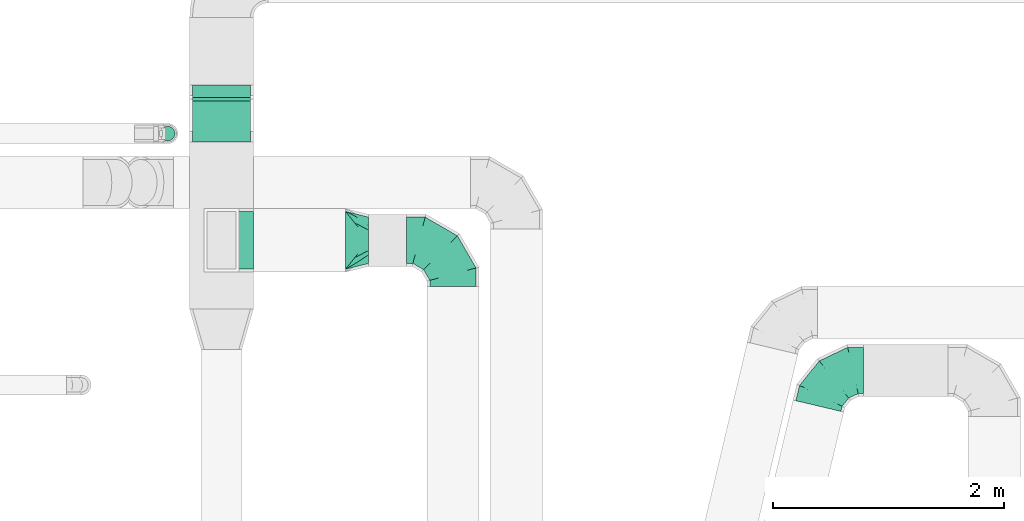
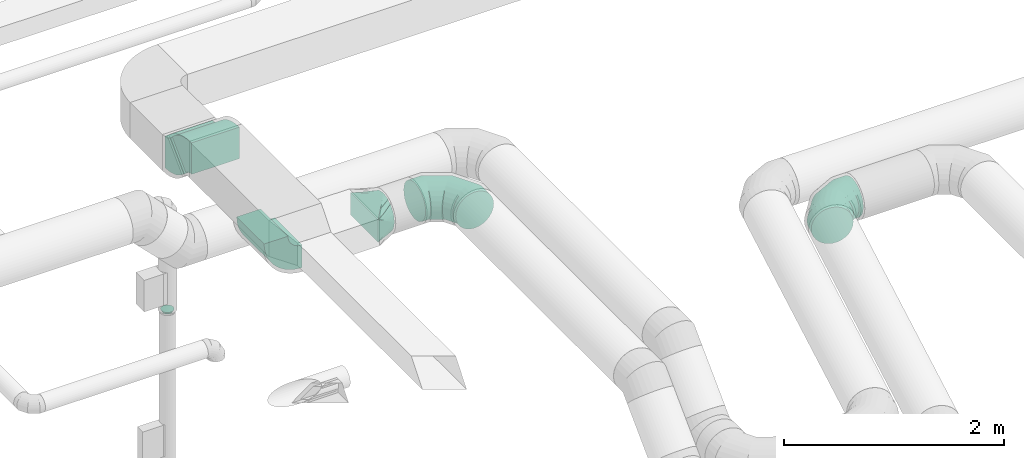
# One storey, part 54 of 97: 7 flow fittings.
"""IFC2X3 building model written with IfcOpenShell, lengths in millimetres."""

from ifc_helpers import new_model, entity, si_unit, converted_unit, derived_unit, direction, frame, frame_2d, origin, place, context, subcontext, project, spatial, polyline, circle_curve, parameter, trimmed, segment, composite_curve, outline, extrude, faceted_brep, source, transform, mapped, material, type_object, type_shapes, element, save


model = new_model("IFC2X3")

# Units and contexts
model_context = context("Model", 3, precision=0.01, world=origin(), true_north=direction((6.12303176911189e-17, 1.0)))
body_context = subcontext(model_context, "Body", "Model", "MODEL_VIEW")
ifc_project = project(units=[si_unit("LENGTHUNIT", "METRE", prefix="MILLI"), si_unit("AREAUNIT", "SQUARE_METRE"), si_unit("VOLUMEUNIT", "CUBIC_METRE"), converted_unit("PLANEANGLEUNIT", "DEGREE", entity("IfcRatioMeasure", 0.0174532925199433), si_unit("PLANEANGLEUNIT", "RADIAN"), dimensions=[0, 0, 0, 0, 0, 0, 0]), si_unit("MASSUNIT", "GRAM", prefix="KILO"), derived_unit("MASSDENSITYUNIT", [(si_unit("MASSUNIT", "GRAM", prefix="KILO"), 1), (si_unit("LENGTHUNIT", "METRE"), -3)]), derived_unit("MOMENTOFINERTIAUNIT", [(si_unit("LENGTHUNIT", "METRE"), 4)]), si_unit("TIMEUNIT", "SECOND"), si_unit("FREQUENCYUNIT", "HERTZ"), si_unit("THERMODYNAMICTEMPERATUREUNIT", "DEGREE_CELSIUS"), derived_unit("THERMALTRANSMITTANCEUNIT", [(si_unit("MASSUNIT", "GRAM", prefix="KILO"), 1), (si_unit("THERMODYNAMICTEMPERATUREUNIT", "KELVIN"), -1), (si_unit("TIMEUNIT", "SECOND"), -3)]), derived_unit("VOLUMETRICFLOWRATEUNIT", [(si_unit("LENGTHUNIT", "METRE"), 3), (si_unit("TIMEUNIT", "SECOND"), -1)]), derived_unit("MASSFLOWRATEUNIT", [(si_unit("MASSUNIT", "GRAM", prefix="KILO"), 1), (si_unit("TIMEUNIT", "SECOND"), -1)]), derived_unit("ROTATIONALFREQUENCYUNIT", [(si_unit("TIMEUNIT", "SECOND"), -1)]), si_unit("ELECTRICCURRENTUNIT", "AMPERE"), si_unit("ELECTRICVOLTAGEUNIT", "VOLT"), si_unit("POWERUNIT", "WATT"), si_unit("FORCEUNIT", "NEWTON", prefix="KILO"), si_unit("ILLUMINANCEUNIT", "LUX"), si_unit("LUMINOUSFLUXUNIT", "LUMEN"), si_unit("LUMINOUSINTENSITYUNIT", "CANDELA"), derived_unit("USERDEFINED", [(si_unit("MASSUNIT", "GRAM", prefix="KILO"), -1), (si_unit("LENGTHUNIT", "METRE"), -2), (si_unit("TIMEUNIT", "SECOND"), 3), (si_unit("LUMINOUSFLUXUNIT", "LUMEN"), 1)]), derived_unit("LINEARVELOCITYUNIT", [(si_unit("LENGTHUNIT", "METRE"), 1), (si_unit("TIMEUNIT", "SECOND"), -1)]), si_unit("PRESSUREUNIT", "PASCAL"), derived_unit("USERDEFINED", [(si_unit("LENGTHUNIT", "METRE"), -2), (si_unit("MASSUNIT", "GRAM", prefix="KILO"), 1), (si_unit("TIMEUNIT", "SECOND"), -2)]), derived_unit("LINEARFORCEUNIT", [(si_unit("MASSUNIT", "GRAM", prefix="KILO"), 1), (si_unit("LENGTHUNIT", "METRE"), 1), (si_unit("TIMEUNIT", "SECOND"), -2), (si_unit("LENGTHUNIT", "METRE"), -1)]), derived_unit("PLANARFORCEUNIT", [(si_unit("MASSUNIT", "GRAM", prefix="KILO"), 1), (si_unit("LENGTHUNIT", "METRE"), 1), (si_unit("TIMEUNIT", "SECOND"), -2), (si_unit("LENGTHUNIT", "METRE"), -2)])], contexts=[model_context])

# Site, building, storey
site_placement = place(None, origin())
site = spatial("IfcSite", under=ifc_project, at=site_placement, CompositionType="ELEMENT")
building_placement = place(site_placement, origin())
building = spatial("IfcBuilding", under=site, at=building_placement, CompositionType="ELEMENT")
storey_placement = place(building_placement, frame((0.0, 0.0, -4900.0)))
storey = spatial("IfcBuildingStorey", under=building, at=storey_placement, CompositionType="ELEMENT", Elevation=-4900.0)

# Flow fittings
ifc_material = material()
duct_fitting_type_1 = type_object("IfcDuctFittingType", PredefinedType="NOTDEFINED", material=ifc_material)
shared_shape_1 = source(origin(), body_context, "Body", "Brep", [
    faceted_brep([(-400.0, 0.0, -200.0), (-400.0, -44.5, -194.99), (-400.0, -86.78, -180.19), (-400.0, -124.7, -156.37), (-400.0, -156.37, -124.7), (-400.0, -180.19, -86.78), (-400.0, -194.99, -44.5), (-400.0, -200.0, 0.0), (-400.0, -194.99, 44.5), (-400.0, -180.19, 86.78), (-400.0, -156.37, 124.7), (-400.0, -124.7, 156.37), (-400.0, -86.78, 180.19), (-400.0, -44.5, 194.99), (-400.0, 0.0, 200.0), (-400.0, 44.5, 194.99), (-400.0, 86.78, 180.19), (-400.0, 124.7, 156.37), (-400.0, 156.37, 124.7), (-400.0, 180.19, 86.78), (-400.0, 194.99, 44.5), (-400.0, 200.0, 0.0), (-400.0, 194.99, -44.5), (-400.0, 180.19, -86.78), (-400.0, 156.37, -124.7), (-400.0, 124.7, -156.37), (-400.0, 86.78, -180.19), (-400.0, 44.5, -194.99), (-292.82, 0.0, 200.0), (-304.75, 44.5, 194.99), (-316.07, 86.78, 180.19), (-326.23, 124.7, 156.37), (-334.72, 156.37, 124.7), (-341.1, 180.19, 86.78), (-345.07, 194.99, 44.5), (-346.41, 200.0, 0.0), (-345.07, 194.99, -44.5), (-341.1, 180.19, -86.78), (-334.72, 156.37, -124.7), (-326.23, 124.7, -156.37), (-316.07, 86.78, -180.19), (-304.75, 44.5, -194.99), (-292.82, 0.0, -200.0), (-280.9, -44.5, -194.99), (-269.57, -86.78, -180.19), (-259.41, -124.7, -156.37), (-250.92, -156.37, -124.7), (-244.54, -180.19, -86.78), (-240.57, -194.99, -44.5), (-239.23, -200.0, 0.0), (-240.57, -194.99, 44.5), (-244.54, -180.19, 86.78), (-250.92, -156.37, 124.7), (-259.41, -124.7, 156.37), (-269.57, -86.78, 180.19), (-280.9, -44.5, 194.99), (-107.18, 107.18, 200.0), (-139.76, 139.76, 194.99), (-170.7, 170.7, 180.19), (-198.46, 198.46, 156.37), (-221.65, 221.65, 124.7), (-239.09, 239.09, 86.78), (-249.92, 249.92, 44.5), (-253.59, 253.59, 0.0), (-249.92, 249.92, -44.5), (-239.09, 239.09, -86.78), (-221.65, 221.65, -124.7), (-198.46, 198.46, -156.37), (-170.7, 170.7, -180.19), (-139.76, 139.76, -194.99), (-107.18, 107.18, -200.0), (-74.6, 74.6, -194.99), (-43.65, 43.65, -180.19), (-15.89, 15.89, -156.37), (7.29, -7.29, -124.7), (24.73, -24.73, -86.78), (35.56, -35.56, -44.5), (39.23, -39.23, 0.0), (35.56, -35.56, 44.5), (24.73, -24.73, 86.78), (7.29, -7.29, 124.7), (-15.89, 15.89, 156.37), (-43.65, 43.65, 180.19), (-74.6, 74.6, 194.99), (0.0, 292.82, 200.0), (-44.5, 304.75, 194.99), (-86.78, 316.07, 180.19), (-124.7, 326.23, 156.37), (-156.37, 334.72, 124.7), (-180.19, 341.1, 86.78), (-194.99, 345.07, 44.5), (-200.0, 346.41, 0.0), (-194.99, 345.07, -44.5), (-180.19, 341.1, -86.78), (-156.37, 334.72, -124.7), (-124.7, 326.23, -156.37), (-86.78, 316.07, -180.19), (-44.5, 304.75, -194.99), (0.0, 292.82, -200.0), (44.5, 280.9, -194.99), (86.78, 269.57, -180.19), (124.7, 259.41, -156.37), (156.37, 250.92, -124.7), (180.19, 244.54, -86.78), (194.99, 240.57, -44.5), (200.0, 239.23, 0.0), (194.99, 240.57, 44.5), (180.19, 244.54, 86.78), (156.37, 250.92, 124.7), (124.7, 259.41, 156.37), (86.78, 269.57, 180.19), (44.5, 280.9, 194.99), (-44.5, 400.0, -194.99), (-86.78, 400.0, -180.19), (-124.7, 400.0, -156.37), (-156.37, 400.0, -124.7), (-180.19, 400.0, -86.78), (-194.99, 400.0, -44.5), (-200.0, 400.0, 0.0), (-194.99, 400.0, 44.5), (-180.19, 400.0, 86.78), (-156.37, 400.0, 124.7), (-124.7, 400.0, 156.37), (-86.78, 400.0, 180.19), (-44.5, 400.0, 194.99), (0.0, 400.0, 200.0), (44.5, 400.0, 194.99), (86.78, 400.0, 180.19), (124.7, 400.0, 156.37), (156.37, 400.0, 124.7), (180.19, 400.0, 86.78), (194.99, 400.0, 44.5), (200.0, 400.0, 0.0), (194.99, 400.0, -44.5), (180.19, 400.0, -86.78), (156.37, 400.0, -124.7), (124.7, 400.0, -156.37), (86.78, 400.0, -180.19), (44.5, 400.0, -194.99), (0.0, 400.0, -200.0)], [[[0, 1, 2, 3, 4, 5, 6, 7, 8, 9, 10, 11, 12, 13, 14, 15, 16, 17, 18, 19, 20, 21, 22, 23, 24, 25, 26, 27]], [[28, 29, 15, 14]], [[30, 31, 17, 16]], [[29, 30, 16, 15]], [[31, 32, 18, 17]], [[32, 33, 19, 18]], [[34, 35, 21, 20]], [[33, 34, 20, 19]], [[35, 36, 22, 21]], [[37, 38, 24, 23]], [[36, 37, 23, 22]], [[38, 39, 25, 24]], [[39, 40, 26, 25]], [[41, 42, 0, 27]], [[40, 41, 27, 26]], [[1, 0, 42, 43]], [[43, 44, 2, 1]], [[45, 3, 2, 44]], [[45, 46, 4, 3]], [[5, 4, 46, 47]], [[47, 48, 6, 5]], [[49, 7, 6, 48]], [[7, 49, 50, 8]], [[8, 50, 51, 9]], [[9, 51, 52, 10]], [[52, 53, 11, 10]], [[11, 53, 54, 12]], [[12, 54, 55, 13]], [[13, 55, 28, 14]], [[56, 57, 29, 28]], [[58, 59, 31, 30]], [[57, 58, 30, 29]], [[59, 60, 32, 31]], [[60, 61, 33, 32]], [[62, 63, 35, 34]], [[61, 62, 34, 33]], [[63, 64, 36, 35]], [[65, 66, 38, 37]], [[64, 65, 37, 36]], [[66, 67, 39, 38]], [[67, 68, 40, 39]], [[69, 70, 42, 41]], [[68, 69, 41, 40]], [[43, 42, 70, 71]], [[71, 72, 44, 43]], [[73, 45, 44, 72]], [[73, 74, 46, 45]], [[47, 46, 74, 75]], [[75, 76, 48, 47]], [[77, 49, 48, 76]], [[50, 49, 77, 78]], [[51, 50, 78, 79]], [[52, 51, 79, 80]], [[80, 81, 53, 52]], [[54, 53, 81, 82]], [[55, 54, 82, 83]], [[28, 55, 83, 56]], [[84, 85, 57, 56]], [[86, 87, 59, 58]], [[85, 86, 58, 57]], [[87, 88, 60, 59]], [[88, 89, 61, 60]], [[90, 91, 63, 62]], [[89, 90, 62, 61]], [[91, 92, 64, 63]], [[93, 94, 66, 65]], [[92, 93, 65, 64]], [[94, 95, 67, 66]], [[95, 96, 68, 67]], [[97, 98, 70, 69]], [[96, 97, 69, 68]], [[71, 70, 98, 99]], [[99, 100, 72, 71]], [[101, 73, 72, 100]], [[101, 102, 74, 73]], [[75, 74, 102, 103]], [[103, 104, 76, 75]], [[105, 77, 76, 104]], [[78, 77, 105, 106]], [[79, 78, 106, 107]], [[80, 79, 107, 108]], [[108, 109, 81, 80]], [[82, 81, 109, 110]], [[83, 82, 110, 111]], [[56, 83, 111, 84]], [[112, 113, 114, 115, 116, 117, 118, 119, 120, 121, 122, 123, 124, 125, 126, 127, 128, 129, 130, 131, 132, 133, 134, 135, 136, 137, 138, 139]], [[85, 84, 125, 124]], [[86, 85, 124, 123]], [[87, 86, 123, 122]], [[122, 121, 88, 87]], [[89, 88, 121, 120]], [[90, 89, 120, 119]], [[91, 90, 119, 118]], [[91, 118, 117, 92]], [[92, 117, 116, 93]], [[93, 116, 115, 94]], [[115, 114, 95, 94]], [[95, 114, 113, 96]], [[96, 113, 112, 97]], [[97, 112, 139, 98]], [[98, 139, 138, 99]], [[99, 138, 137, 100]], [[100, 137, 136, 101]], [[136, 135, 102, 101]], [[102, 135, 134, 103]], [[103, 134, 133, 104]], [[104, 133, 132, 105]], [[106, 105, 132, 131]], [[107, 106, 131, 130]], [[108, 107, 130, 129]], [[129, 128, 109, 108]], [[110, 109, 128, 127]], [[111, 110, 127, 126]], [[84, 111, 126, 125]]]),
])
type_shapes(duct_fitting_type_1, [shared_shape_1])
flow_fitting_1_placement = place(storey_placement, frame((51464.16, 6223.55, 3600.0), z_axis=(-2.94897001082476e-08, 0.0, 1.0), x_axis=(0.0, 1.0, 0.0)))
element("IfcFlowFitting", 1, at=flow_fitting_1_placement, inside=storey, type_object=duct_fitting_type_1, material=ifc_material, context=body_context, shape_type="MappedRepresentation", body=[
    mapped(shared_shape_1, transform((0.0, 0.0, 0.0), scale=1.0)),
])
duct_fitting_type_2 = type_object("IfcDuctFittingType", PredefinedType="NOTDEFINED", material=ifc_material)
shared_shape_2 = source(origin(), body_context, "Body", "Brep", [
    faceted_brep([(200.0, 44.5, 194.99), (200.0, 31.87, 196.41), (200.0, 19.23, 197.83), (200.0, 0.0, 200.0), (200.0, -19.23, 197.83), (200.0, -31.87, 196.41), (200.0, -44.5, 194.99), (200.0, -65.64, 187.59), (200.0, -86.78, 180.19), (200.0, -105.74, 168.28), (200.0, -124.7, 156.37), (200.0, -140.53, 140.53), (200.0, -156.37, 124.7), (200.0, -168.28, 105.74), (200.0, -180.19, 86.78), (200.0, -187.59, 65.64), (200.0, -194.99, 44.5), (200.0, -196.41, 31.87), (200.0, -197.83, 19.23), (200.0, -200.0, 0.0), (200.0, -197.83, -19.23), (200.0, -196.41, -31.87), (200.0, -194.99, -44.5), (200.0, -187.59, -65.64), (200.0, -180.19, -86.78), (200.0, -168.28, -105.74), (200.0, -156.37, -124.7), (200.0, -140.53, -140.53), (200.0, -124.7, -156.37), (200.0, -105.74, -168.28), (200.0, -86.78, -180.19), (200.0, -65.64, -187.59), (200.0, -44.5, -194.99), (200.0, -31.87, -196.41), (200.0, -19.23, -197.83), (200.0, 0.0, -200.0), (200.0, 19.23, -197.83), (200.0, 31.87, -196.41), (200.0, 44.5, -194.99), (200.0, 65.64, -187.59), (200.0, 86.78, -180.19), (200.0, 105.74, -168.28), (200.0, 124.7, -156.37), (200.0, 140.53, -140.53), (200.0, 156.37, -124.7), (200.0, 168.28, -105.74), (200.0, 180.19, -86.78), (200.0, 187.59, -65.64), (200.0, 194.99, -44.5), (200.0, 196.41, -31.87), (200.0, 197.83, -19.23), (200.0, 200.0, 0.0), (200.0, 197.83, 19.23), (200.0, 196.41, 31.87), (200.0, 194.99, 44.5), (200.0, 187.59, 65.64), (200.0, 180.19, 86.78), (200.0, 168.28, 105.74), (200.0, 156.37, 124.7), (200.0, 140.53, 140.53), (200.0, 124.7, 156.37), (200.0, 105.74, 168.28), (200.0, 86.78, 180.19), (200.0, 65.64, 187.59), (0.0, -250.0, 125.0), (0.0, 250.0, 125.0), (0.0, 250.0, -125.0), (0.0, -250.0, -125.0), (128.09, -217.98, 44.95), (104.11, -223.97, 59.93), (78.09, -152.39, 154.28), (52.06, -184.93, 144.52), (152.06, -211.99, 29.96), (164.04, -208.99, 22.47), (176.03, -205.99, 14.98), (128.09, -89.89, 173.03), (164.04, -44.95, 186.52), (152.06, -59.93, 182.02), (176.03, -29.96, 191.01), (26.03, -243.49, 108.73), (100.0, -191.3, 137.36), (26.03, -217.46, 134.76), (52.06, -236.99, 92.46), (104.11, -119.86, 164.04), (78.09, -230.48, 76.2), (26.03, -243.49, -108.73), (52.06, -236.99, -92.46), (78.09, -230.48, -76.2), (104.11, -223.97, -59.93), (128.09, -217.98, -44.95), (152.06, -211.99, -29.96), (164.04, -208.99, -22.47), (176.03, -205.99, -14.98), (128.09, -89.89, -173.03), (104.11, -119.86, -164.04), (152.06, -59.93, -182.02), (164.04, -44.95, -186.52), (176.03, -29.96, -191.01), (26.03, -217.46, -134.76), (100.0, -199.86, -128.8), (52.06, -184.93, -144.52), (78.09, -152.39, -154.28), (26.03, 217.46, -134.76), (52.06, 184.93, -144.52), (78.09, 152.39, -154.28), (104.11, 119.86, -164.04), (128.09, 89.89, -173.03), (152.06, 59.93, -182.02), (164.04, 44.95, -186.52), (176.03, 29.96, -191.01), (128.09, 217.98, -44.95), (104.11, 223.97, -59.93), (152.06, 211.99, -29.96), (164.04, 208.99, -22.47), (176.03, 205.99, -14.98), (26.03, 243.49, -108.73), (100.0, 191.3, -137.36), (52.06, 236.99, -92.46), (78.09, 230.48, -76.2), (26.03, 243.49, 108.73), (52.06, 236.99, 92.46), (78.09, 230.48, 76.2), (104.11, 223.97, 59.93), (128.09, 217.98, 44.95), (152.06, 211.99, 29.96), (164.04, 208.99, 22.47), (176.03, 205.99, 14.98), (128.09, 89.89, 173.03), (104.11, 119.86, 164.04), (152.06, 59.93, 182.02), (164.04, 44.95, 186.52), (176.03, 29.96, 191.01), (26.03, 217.46, 134.76), (100.0, 199.86, 128.8), (52.06, 184.93, 144.52), (78.09, 152.39, 154.28)], [[[0, 1, 2, 3, 4, 5, 6, 7, 8, 9, 10, 11, 12, 13, 14, 15, 16, 17, 18, 19, 20, 21, 22, 23, 24, 25, 26, 27, 28, 29, 30, 31, 32, 33, 34, 35, 36, 37, 38, 39, 40, 41, 42, 43, 44, 45, 46, 47, 48, 49, 50, 51, 52, 53, 54, 55, 56, 57, 58, 59, 60, 61, 62, 63]], [[64, 65, 66, 67]], [[68, 15, 69]], [[9, 70, 71]], [[16, 68, 72, 73, 74, 19, 18, 17]], [[6, 75, 7]], [[76, 77, 75, 6, 5, 4, 3, 78]], [[79, 12, 80]], [[80, 12, 11, 10]], [[10, 71, 81]], [[79, 82, 12]], [[8, 70, 9]], [[69, 15, 14]], [[83, 8, 7]], [[83, 7, 75]], [[68, 16, 15]], [[8, 83, 70]], [[84, 13, 82]], [[84, 69, 14]], [[64, 80, 81]], [[81, 80, 10]], [[79, 80, 64]], [[71, 10, 9]], [[13, 84, 14]], [[13, 12, 82]], [[74, 73, 72, 68, 69, 84, 82, 79, 64, 67, 85, 86, 87, 88, 89, 90, 91, 92, 19]], [[93, 31, 94]], [[25, 87, 86]], [[32, 93, 95, 96, 97, 35, 34, 33]], [[22, 89, 23]], [[91, 90, 89, 22, 21, 20, 19, 92]], [[98, 28, 99]], [[99, 28, 27, 26]], [[26, 86, 85]], [[98, 100, 28]], [[24, 87, 25]], [[94, 31, 30]], [[88, 24, 23]], [[88, 23, 89]], [[93, 32, 31]], [[24, 88, 87]], [[101, 29, 100]], [[101, 94, 30]], [[67, 99, 85]], [[85, 99, 26]], [[98, 99, 67]], [[86, 26, 25]], [[29, 101, 30]], [[29, 28, 100]], [[97, 96, 95, 93, 94, 101, 100, 98, 67, 66, 102, 103, 104, 105, 106, 107, 108, 109, 35]], [[110, 47, 111]], [[41, 104, 103]], [[48, 110, 112, 113, 114, 51, 50, 49]], [[38, 106, 39]], [[108, 107, 106, 38, 37, 36, 35, 109]], [[115, 44, 116]], [[116, 44, 43, 42]], [[42, 103, 102]], [[115, 117, 44]], [[40, 104, 41]], [[111, 47, 46]], [[105, 40, 39]], [[105, 39, 106]], [[110, 48, 47]], [[40, 105, 104]], [[118, 45, 117]], [[118, 111, 46]], [[66, 116, 102]], [[102, 116, 42]], [[115, 116, 66]], [[103, 42, 41]], [[45, 118, 46]], [[45, 44, 117]], [[66, 65, 119, 120, 121, 122, 123, 124, 125, 126, 51, 114, 113, 112, 110, 111, 118, 117, 115]], [[127, 63, 128]], [[57, 121, 120]], [[0, 127, 129, 130, 131, 3, 2, 1]], [[54, 123, 55]], [[125, 124, 123, 54, 53, 52, 51, 126]], [[132, 60, 133]], [[133, 60, 59, 58]], [[58, 120, 119]], [[132, 134, 60]], [[56, 121, 57]], [[128, 63, 62]], [[122, 56, 55]], [[122, 55, 123]], [[127, 0, 63]], [[56, 122, 121]], [[135, 61, 134]], [[135, 128, 62]], [[65, 133, 119]], [[119, 133, 58]], [[132, 133, 65]], [[120, 58, 57]], [[61, 135, 62]], [[61, 60, 134]], [[65, 64, 81, 71, 70, 83, 75, 77, 76, 78, 3, 131, 130, 129, 127, 128, 135, 134, 132]]]),
])
type_shapes(duct_fitting_type_2, [shared_shape_2])
flow_fitting_2_placement = place(storey_placement, frame((50535.84, 6223.55, 3600.0)))
element("IfcFlowFitting", 2, at=flow_fitting_2_placement, inside=storey, type_object=duct_fitting_type_2, material=ifc_material, context=body_context, shape_type="MappedRepresentation", body=[
    mapped(shared_shape_2, transform((0.0, 0.0, 0.0), scale=1.0)),
])
duct_fitting_type_3 = type_object("IfcDuctFittingType", PredefinedType="NOTDEFINED", material=ifc_material)
shared_shape_3 = source(origin(), body_context, "Body", "Brep", [
    faceted_brep([(-316.33, 0.0, -200.0), (-316.33, -44.5, -194.99), (-316.33, -86.78, -180.19), (-316.33, -124.7, -156.37), (-316.33, -156.37, -124.7), (-316.33, -180.19, -86.78), (-316.33, -194.99, -44.5), (-316.33, -200.0, 0.0), (-316.33, -194.99, 44.5), (-316.33, -180.19, 86.78), (-316.33, -156.37, 124.7), (-316.33, -124.7, 156.37), (-316.33, -86.78, 180.19), (-316.33, -44.5, 194.99), (-316.33, 0.0, 200.0), (-316.33, 44.5, 194.99), (-316.33, 86.78, 180.19), (-316.33, 124.7, 156.37), (-316.33, 156.37, 124.7), (-316.33, 180.19, 86.78), (-316.33, 194.99, 44.5), (-316.33, 200.0, 0.0), (-316.33, 194.99, -44.5), (-316.33, 180.19, -86.78), (-316.33, 156.37, -124.7), (-316.33, 124.7, -156.37), (-316.33, 86.78, -180.19), (-316.33, 44.5, -194.99), (-225.6, 0.0, 200.0), (-235.7, 44.5, 194.99), (-245.29, 86.78, 180.19), (-253.89, 124.7, 156.37), (-261.07, 156.37, 124.7), (-266.47, 180.19, 86.78), (-269.83, 194.99, 44.5), (-270.97, 200.0, 0.0), (-269.83, 194.99, -44.5), (-266.47, 180.19, -86.78), (-261.07, 156.37, -124.7), (-253.89, 124.7, -156.37), (-245.29, 86.78, -180.19), (-235.7, 44.5, -194.99), (-225.6, 0.0, -200.0), (-215.51, -44.5, -194.99), (-205.92, -86.78, -180.19), (-197.32, -124.7, -156.37), (-190.14, -156.37, -124.7), (-184.73, -180.19, -86.78), (-181.38, -194.99, -44.5), (-180.24, -200.0, 0.0), (-181.38, -194.99, 44.5), (-184.73, -180.19, 86.78), (-190.14, -156.37, 124.7), (-197.32, -124.7, 156.37), (-205.92, -86.78, 180.19), (-215.51, -44.5, 194.99), (-61.91, 78.28, 200.0), (-90.22, 114.08, 194.99), (-117.1, 148.08, 180.19), (-141.22, 178.58, 156.37), (-161.37, 204.05, 124.7), (-176.52, 223.21, 86.78), (-185.93, 235.11, 44.5), (-189.12, 239.14, 0.0), (-185.93, 235.11, -44.5), (-176.52, 223.21, -86.78), (-161.37, 204.05, -124.7), (-141.22, 178.58, -156.37), (-117.1, 148.08, -180.19), (-90.22, 114.08, -194.99), (-61.91, 78.28, -200.0), (-33.6, 42.49, -194.99), (-6.71, 8.49, -180.19), (17.41, -22.01, -156.37), (37.55, -47.48, -124.7), (52.7, -66.64, -86.78), (62.11, -78.54, -44.5), (65.3, -82.57, 0.0), (62.11, -78.54, 44.5), (52.7, -66.64, 86.78), (37.55, -47.48, 124.7), (17.41, -22.01, 156.37), (-6.71, 8.49, 180.19), (-33.6, 42.49, 194.99), (51.99, 219.53, 200.0), (11.01, 239.61, 194.99), (-27.91, 258.68, 180.19), (-62.83, 275.79, 156.37), (-91.99, 290.08, 124.7), (-113.93, 300.83, 86.78), (-127.55, 307.5, 44.5), (-132.17, 309.77, 0.0), (-127.55, 307.5, -44.5), (-113.93, 300.83, -86.78), (-91.99, 290.08, -124.7), (-62.83, 275.79, -156.37), (-27.91, 258.68, -180.19), (11.01, 239.61, -194.99), (51.99, 219.53, -200.0), (92.97, 199.45, -194.99), (131.9, 180.38, -180.19), (166.82, 163.27, -156.37), (195.98, 148.98, -124.7), (217.92, 138.23, -86.78), (231.54, 131.56, -44.5), (236.16, 129.3, 0.0), (231.54, 131.56, 44.5), (217.92, 138.23, 86.78), (195.98, 148.98, 124.7), (166.82, 163.27, 156.37), (131.9, 180.38, 180.19), (92.97, 199.45, 194.99), (-116.83, 352.75, 44.5), (-102.44, 349.34, 86.78), (-79.25, 343.85, 124.7), (-48.44, 336.55, 156.37), (-11.54, 327.81, 180.19), (29.6, 318.07, 194.99), (72.9, 307.81, 200.0), (116.21, 297.56, 194.99), (157.34, 287.81, 180.19), (194.24, 279.07, 156.37), (225.06, 271.78, 124.7), (248.25, 266.28, 86.78), (262.64, 262.88, 44.5), (267.52, 261.72, 0.0), (262.64, 262.88, -44.5), (248.25, 266.28, -86.78), (225.06, 271.78, -124.7), (194.24, 279.07, -156.37), (157.34, 287.81, -180.19), (116.21, 297.56, -194.99), (72.9, 307.81, -200.0), (29.6, 318.07, -194.99), (-11.54, 327.81, -180.19), (-48.44, 336.55, -156.37), (-79.25, 343.85, -124.7), (-102.44, 349.34, -86.78), (-116.83, 352.75, -44.5), (-121.71, 353.91, 0.0)], [[[0, 1, 2, 3, 4, 5, 6, 7, 8, 9, 10, 11, 12, 13, 14, 15, 16, 17, 18, 19, 20, 21, 22, 23, 24, 25, 26, 27]], [[28, 29, 15, 14]], [[30, 31, 17, 16]], [[29, 30, 16, 15]], [[31, 32, 18, 17]], [[32, 33, 19, 18]], [[34, 35, 21, 20]], [[33, 34, 20, 19]], [[35, 36, 22, 21]], [[37, 38, 24, 23]], [[36, 37, 23, 22]], [[38, 39, 25, 24]], [[39, 40, 26, 25]], [[41, 42, 0, 27]], [[40, 41, 27, 26]], [[1, 0, 42, 43]], [[43, 44, 2, 1]], [[45, 3, 2, 44]], [[45, 46, 4, 3]], [[5, 4, 46, 47]], [[47, 48, 6, 5]], [[49, 7, 6, 48]], [[7, 49, 50, 8]], [[8, 50, 51, 9]], [[9, 51, 52, 10]], [[52, 53, 11, 10]], [[11, 53, 54, 12]], [[12, 54, 55, 13]], [[13, 55, 28, 14]], [[56, 57, 29, 28]], [[58, 59, 31, 30]], [[57, 58, 30, 29]], [[59, 60, 32, 31]], [[60, 61, 33, 32]], [[62, 63, 35, 34]], [[61, 62, 34, 33]], [[63, 64, 36, 35]], [[65, 66, 38, 37]], [[64, 65, 37, 36]], [[66, 67, 39, 38]], [[67, 68, 40, 39]], [[69, 70, 42, 41]], [[68, 69, 41, 40]], [[43, 42, 70, 71]], [[71, 72, 44, 43]], [[73, 45, 44, 72]], [[73, 74, 46, 45]], [[47, 46, 74, 75]], [[75, 76, 48, 47]], [[77, 49, 48, 76]], [[50, 49, 77, 78]], [[51, 50, 78, 79]], [[52, 51, 79, 80]], [[80, 81, 53, 52]], [[54, 53, 81, 82]], [[55, 54, 82, 83]], [[28, 55, 83, 56]], [[84, 85, 57, 56]], [[86, 87, 59, 58]], [[85, 86, 58, 57]], [[87, 88, 60, 59]], [[88, 89, 61, 60]], [[90, 91, 63, 62]], [[89, 90, 62, 61]], [[91, 92, 64, 63]], [[93, 94, 66, 65]], [[92, 93, 65, 64]], [[94, 95, 67, 66]], [[95, 96, 68, 67]], [[97, 98, 70, 69]], [[96, 97, 69, 68]], [[71, 70, 98, 99]], [[99, 100, 72, 71]], [[101, 73, 72, 100]], [[101, 102, 74, 73]], [[75, 74, 102, 103]], [[103, 104, 76, 75]], [[105, 77, 76, 104]], [[78, 77, 105, 106]], [[79, 78, 106, 107]], [[80, 79, 107, 108]], [[108, 109, 81, 80]], [[82, 81, 109, 110]], [[83, 82, 110, 111]], [[56, 83, 111, 84]], [[112, 113, 114, 115, 116, 117, 118, 119, 120, 121, 122, 123, 124, 125, 126, 127, 128, 129, 130, 131, 132, 133, 134, 135, 136, 137, 138, 139]], [[85, 84, 118, 117]], [[116, 115, 87, 86]], [[86, 85, 117, 116]], [[115, 114, 88, 87]], [[89, 88, 114, 113]], [[90, 89, 113, 112]], [[91, 90, 112, 139]], [[91, 139, 138, 92]], [[138, 137, 93, 92]], [[136, 94, 93, 137]], [[136, 135, 95, 94]], [[95, 135, 134, 96]], [[96, 134, 133, 97]], [[97, 133, 132, 98]], [[98, 132, 131, 99]], [[99, 131, 130, 100]], [[100, 130, 129, 101]], [[129, 128, 102, 101]], [[102, 128, 127, 103]], [[103, 127, 126, 104]], [[104, 126, 125, 105]], [[106, 105, 125, 124]], [[107, 106, 124, 123]], [[108, 107, 123, 122]], [[122, 121, 109, 108]], [[110, 109, 121, 120]], [[111, 110, 120, 119]], [[84, 111, 119, 118]]]),
])
type_shapes(duct_fitting_type_3, [shared_shape_3])
flow_fitting_3_placement = place(storey_placement, frame((54696.83, 5098.32, 2950.0), z_axis=(0.0, 0.0, 1.0), x_axis=(-1.0, 0.0, 0.0)))
element("IfcFlowFitting", 3, at=flow_fitting_3_placement, inside=storey, type_object=duct_fitting_type_3, material=ifc_material, context=body_context, shape_type="MappedRepresentation", body=[
    mapped(shared_shape_3, transform((0.0, 0.0, 0.0), scale=1.0)),
])
duct_fitting_type_4 = type_object("IfcDuctFittingType", PredefinedType="NOTDEFINED", material=ifc_material)
shared_shape_4 = source(origin(), body_context, "Body", "Brep", [
    faceted_brep([(25.0, -46.19, 19.13), (25.0, -48.1, 9.57), (25.0, -50.0, 0.0), (25.0, -48.1, -9.57), (25.0, -46.19, -19.13), (25.0, -40.77, -27.24), (25.0, -35.36, -35.36), (25.0, -27.24, -40.77), (25.0, -19.13, -46.19), (25.0, -9.57, -48.1), (25.0, 0.0, -50.0), (25.0, 9.57, -48.1), (25.0, 19.13, -46.19), (25.0, 27.24, -40.77), (25.0, 35.36, -35.36), (25.0, 40.77, -27.24), (25.0, 46.19, -19.13), (25.0, 48.1, -9.57), (25.0, 50.0, 0.0), (25.0, 48.1, 9.57), (25.0, 46.19, 19.13), (25.0, 40.77, 27.24), (25.0, 35.36, 35.36), (25.0, 27.24, 40.77), (25.0, 19.13, 46.19), (25.0, 9.57, 48.1), (25.0, 0.0, 50.0), (25.0, -9.57, 48.1), (25.0, -19.13, 46.19), (25.0, -27.24, 40.77), (25.0, -35.36, 35.36), (25.0, -40.77, 27.24), (0.0, -62.5, 0.0), (0.0, -60.02, 12.45), (0.0, -57.74, 23.92), (0.0, -50.97, 34.06), (0.0, -44.19, 44.19), (0.0, -34.06, 50.97), (0.0, -23.92, 57.74), (0.0, -12.45, 60.02), (0.0, 0.0, 62.5), (0.0, 12.45, 60.02), (0.0, 23.92, 57.74), (0.0, 34.06, 50.97), (0.0, 44.19, 44.19), (0.0, 50.97, 34.06), (0.0, 57.74, 23.92), (0.0, 60.02, 12.45), (0.0, 62.5, 0.0), (0.0, 60.02, -12.45), (0.0, 57.74, -23.92), (0.0, 50.97, -34.06), (0.0, 44.19, -44.19), (0.0, 34.06, -50.97), (0.0, 23.92, -57.74), (0.0, 12.45, -60.02), (0.0, 0.0, -62.5), (0.0, -12.45, -60.02), (0.0, -23.92, -57.74), (0.0, -34.06, -50.97), (0.0, -44.19, -44.19), (0.0, -50.97, -34.06), (0.0, -57.74, -23.92), (0.0, -60.02, -12.45)], [[[0, 1, 2, 3, 4, 5, 6, 7, 8, 9, 10, 11, 12, 13, 14, 15, 16, 17, 18, 19, 20, 21, 22, 23, 24, 25, 26, 27, 28, 29, 30, 31]], [[32, 33, 34, 35, 36, 37, 38, 39, 40, 41, 42, 43, 44, 45, 46, 47, 48, 49, 50, 51, 52, 53, 54, 55, 56, 57, 58, 59, 60, 61, 62, 63]], [[24, 42, 41, 40, 26, 25]], [[22, 44, 43, 42, 24, 23]], [[48, 47, 46, 20, 19, 18]], [[44, 22, 21, 20, 46, 45]], [[0, 34, 33, 32, 2, 1]], [[30, 36, 35, 34, 0, 31]], [[40, 39, 38, 28, 27, 26]], [[36, 30, 29, 28, 38, 37]], [[8, 58, 57, 56, 10, 9]], [[6, 60, 59, 58, 8, 7]], [[32, 63, 62, 4, 3, 2]], [[60, 6, 5, 4, 62, 61]], [[16, 50, 49, 48, 18, 17]], [[14, 52, 51, 50, 16, 15]], [[56, 55, 54, 12, 11, 10]], [[52, 14, 13, 12, 54, 53]]]),
])
type_shapes(duct_fitting_type_4, [shared_shape_4])
flow_fitting_4_placement = place(storey_placement, frame((48999.38, 7146.24, 2565.0), z_axis=(1.0, 0.0, 0.0), x_axis=(0.0, 0.0, -1.0)))
element("IfcFlowFitting", 4, at=flow_fitting_4_placement, inside=storey, type_object=duct_fitting_type_4, material=ifc_material, context=body_context, shape_type="MappedRepresentation", body=[
    mapped(shared_shape_4, transform((0.0, 0.0, 0.0), scale=1.0)),
])
duct_fitting_type_5 = type_object("IfcDuctFittingType", PredefinedType="NOTDEFINED", material=ifc_material)
shared_shape_5 = source(origin(), body_context, "Body", "SweptSolid", [
    extrude(outline(composite_curve([segment(polyline([(-222.6, -114.9), (127.4, -114.9)]), True, "CONTINUOUS"), segment(trimmed(circle_curve(frame_2d((277.4, -114.9), x_axis=(-0.707106781186553, 0.707106781186546)), 150.0), [parameter(0.0)], [parameter(45.0)], True, "PARAMETER"), False, "CONTINUOUS"), segment(polyline([(171.34, -8.84), (-76.15, 238.65)]), True, "CONTINUOUS"), segment(trimmed(circle_curve(frame_2d((277.4, -114.9), x_axis=(-0.707106781186553, 0.707106781186546)), 500.0), [parameter(0.0)], [parameter(45.0)], True, "PARAMETER"), True, "CONTINUOUS")], self_intersect=False)), frame((-19.71, 47.6, -250.0), z_axis=(0.0, 0.0, 1.0), x_axis=(-0.707106781186547, 0.707106781186548, 0.0)), (0.0, 0.0, 1.0), 500.0),
])
type_shapes(duct_fitting_type_5, [shared_shape_5])
for number, where, z_axis, x_axis in (
    (5, (49463.6, 7429.46, 3980.0), (-1.0, 0.0, 0.0), (0.0, -1.0, 0.0)),
    (6, (49463.6, 7209.46, 4200.0), (1.0, 0.0, 0.0), (0.0, -0.70710678118654, 0.707106781186555)),
):
    element("IfcFlowFitting", number, at=place(storey_placement, frame(where, z_axis=z_axis, x_axis=x_axis)), inside=storey, type_object=duct_fitting_type_5, material=ifc_material, context=body_context, shape_type="MappedRepresentation", body=[
        mapped(shared_shape_5, transform((0.0, 0.0, 0.0), scale=1.0)),
    ])
duct_fitting_type_6 = type_object("IfcDuctFittingType", PredefinedType="NOTDEFINED", material=ifc_material)
shared_shape_6 = source(origin(), body_context, "Body", "SweptSolid", [
    extrude(outline(composite_curve([segment(polyline([(-262.5, -137.5), (-12.5, -137.5)]), True, "CONTINUOUS"), segment(trimmed(circle_curve(frame_2d((137.5, -137.5), x_axis=(0.0, 1.0)), 150.0), [parameter(0.0)], [parameter(90.0000000000001)], True, "PARAMETER"), False, "CONTINUOUS"), segment(polyline([(137.5, 12.5), (137.5, 262.5)]), True, "CONTINUOUS"), segment(trimmed(circle_curve(frame_2d((137.5, -137.5), x_axis=(0.0, 1.0)), 400.0), [parameter(0.0)], [parameter(90.0000000000001)], True, "PARAMETER"), True, "CONTINUOUS")], self_intersect=False)), frame((-137.5, 137.5, -250.0), z_axis=(0.0, 0.0, 1.0), x_axis=(-1.0, 0.0, 0.0)), (0.0, 0.0, 1.0), 500.0),
])
type_shapes(duct_fitting_type_6, [shared_shape_6])
flow_fitting_5_placement = place(storey_placement, frame((49463.6, 6223.55, 3600.0), z_axis=(0.0, -1.0, 0.0), x_axis=(0.0, 0.0, -1.0)))
element("IfcFlowFitting", 7, at=flow_fitting_5_placement, inside=storey, type_object=duct_fitting_type_6, material=ifc_material, context=body_context, shape_type="MappedRepresentation", body=[
    mapped(shared_shape_6, transform((0.0, 0.0, 0.0), scale=1.0)),
])

save(model, "model.ifc")
